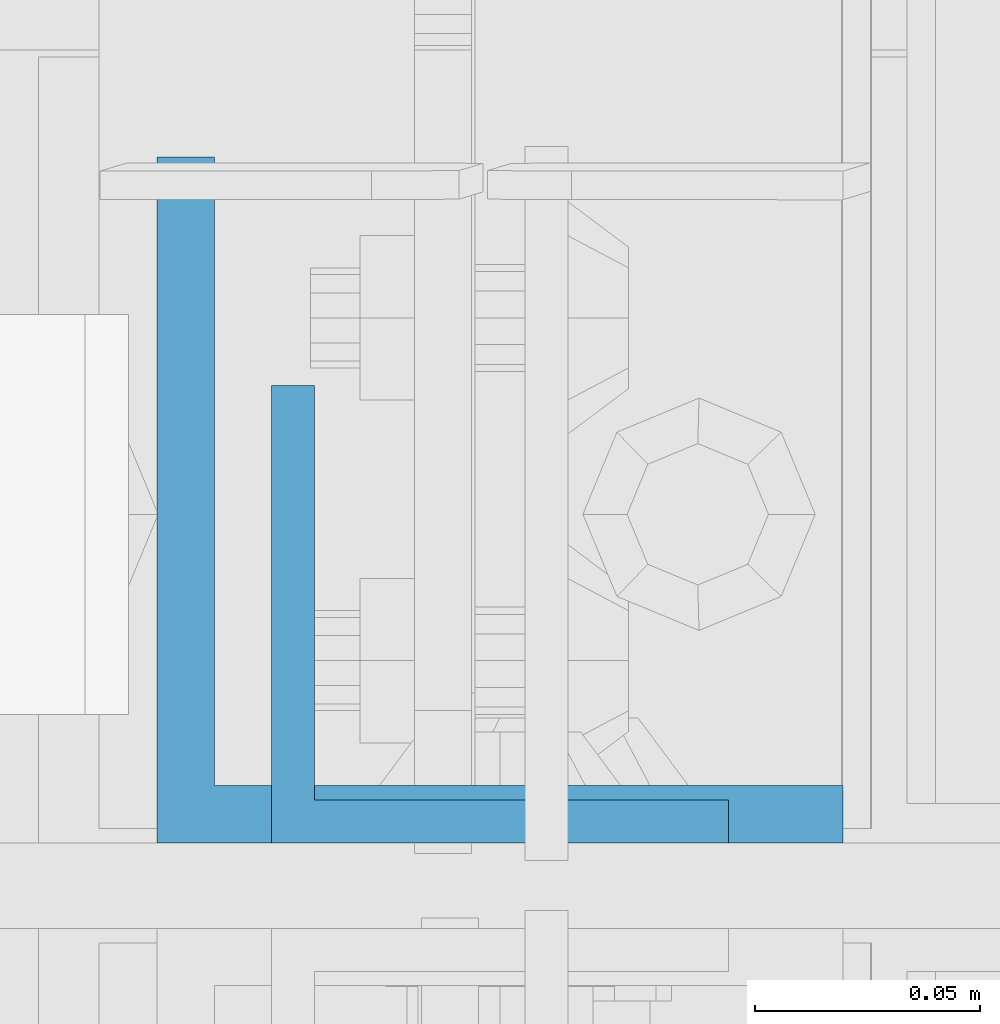
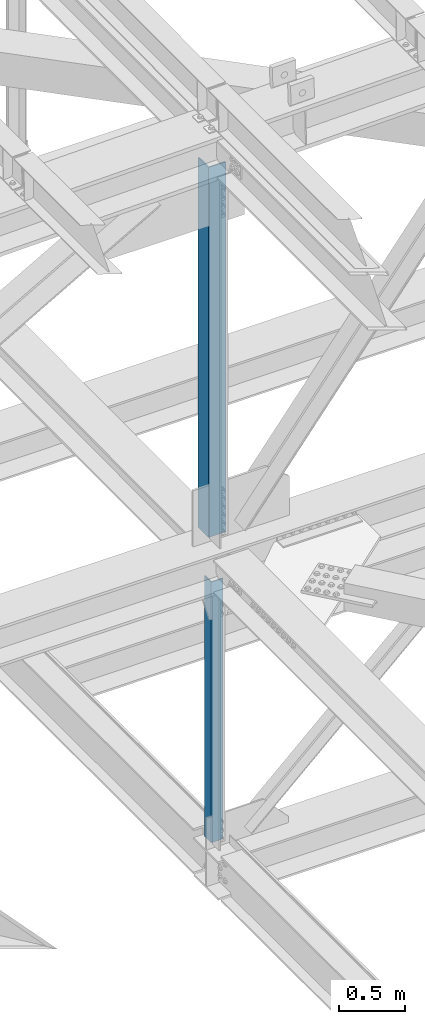
# One storey, part 1835 of 3843: 2 beams, 2 elements without a shape of their own.
"""IFC2X3 building model written with IfcOpenShell, lengths in millimetres."""

from ifc_helpers import new_model, si_unit, frame, origin_with_axes, place, context, subcontext, project, spatial, faceted_brep, material, type_object, element, aggregate, save


model = new_model("IFC2X3")

# Units and contexts
model_context = context("Model", 3, precision=1e-05, world=origin_with_axes())
body_context = subcontext(model_context, "Body", "Model", "MODEL_VIEW")
ifc_project = project(units=[si_unit("LENGTHUNIT", "METRE", prefix="MILLI"), si_unit("AREAUNIT", "SQUARE_METRE"), si_unit("VOLUMEUNIT", "CUBIC_METRE"), si_unit("MASSUNIT", "GRAM", prefix="KILO"), si_unit("TIMEUNIT", "SECOND"), si_unit("PLANEANGLEUNIT", "RADIAN"), si_unit("SOLIDANGLEUNIT", "STERADIAN"), si_unit("THERMODYNAMICTEMPERATUREUNIT", "DEGREE_CELSIUS"), si_unit("LUMINOUSINTENSITYUNIT", "LUMEN")], contexts=[model_context])

# Site, building, storey
site_placement = place(None, origin_with_axes())
site = spatial("IfcSite", under=ifc_project, at=site_placement, CompositionType="ELEMENT")
building_placement = place(site_placement, origin_with_axes())
building = spatial("IfcBuilding", under=site, at=building_placement, Name="Undefined", CompositionType="ELEMENT")
storey_placement = place(building_placement, origin_with_axes())
storey = spatial("IfcBuildingStorey", under=building, at=storey_placement, Name="Undefined", CompositionType="ELEMENT", Elevation=0.0)

# Assembly, beam
assembly_1_placement = place(storey_placement, origin_with_axes())
assembly_1 = element("IfcElementAssembly", 1, at=assembly_1_placement, inside=storey, Name="ANGLE", AssemblyPlace="NOTDEFINED", PredefinedType="RIGID_FRAME")
ifc_material = material(Name="STEEL/A572-50")
beam_type_1 = type_object("IfcBeamType", Name="L4X4X3/8", PredefinedType="NOTDEFINED")
beam_1_placement = place(assembly_1_placement, frame((77012.800000028, 33905.825, 42266.0734958762), z_axis=(0.0, 1.0, 0.0), x_axis=(0.0, 0.0, -1.0)))
beam_1 = element("IfcBeam", 2, at=beam_1_placement, type_object=beam_type_1, material=ifc_material, Name="ANGLE", ObjectType="L4X4X3/8", context=body_context, shape_type="Brep", body=[
    faceted_brep([(209.574551470876, 50.8000000000029, -50.8000000000029), (209.574551470876, 50.8000000000029, 50.8000000000029), (2603.58821558402, 50.8000000000029, 50.8000000000029), (2603.58821558402, 50.8000000000029, -50.8000000000029), (209.574551470876, 41.2749999999942, 50.8000000000029), (2603.58821558402, 41.2749999999942, 50.8000000000029), (209.574551470876, 41.2749999999942, -41.2750000000015), (2603.58821558402, 41.2749999999942, -41.2750000000015), (209.574551470876, -50.8000000000029, -41.2750000000015), (2603.58821558402, -50.8000000000029, -41.2750000000015), (209.574551470876, -50.8000000000029, -50.8000000000029), (2603.58821558402, -50.8000000000029, -50.8000000000029)], [[[0, 1, 2, 3]], [[1, 4, 5, 2]], [[4, 6, 7, 5]], [[6, 8, 9, 7]], [[8, 10, 11, 9]], [[10, 0, 3, 11]], [[5, 7, 9, 11, 3, 2]], [[10, 8, 6, 4, 1, 0]]]),
])
aggregate(assembly_1, [beam_1])

assembly_2_placement = place(storey_placement, origin_with_axes())
assembly_2 = element("IfcElementAssembly", 3, at=assembly_2_placement, inside=storey, Name="ANGLE", AssemblyPlace="NOTDEFINED", PredefinedType="RIGID_FRAME")
beam_type_2 = type_object("IfcBeamType", Name="L6X6X1/2", PredefinedType="NOTDEFINED")
beam_2_placement = place(assembly_2_placement, frame((77012.8, 33931.225, 46096.5035436108), z_axis=(0.0, 1.0, 0.0), x_axis=(0.0, 0.0, -1.0)))
beam_2 = element("IfcBeam", 4, at=beam_2_placement, type_object=beam_type_2, material=ifc_material, Name="ANGLE", ObjectType="L6X6X1/2", context=body_context, shape_type="Brep", body=[
    faceted_brep([(224.072059462451, 76.1999999999971, -76.1999999999971), (224.072059462451, 76.1999999999971, 76.1999999999971), (3621.52260546288, 76.1999999999971, 76.1999999999971), (3621.52260546288, 76.1999999999971, -76.1999999999971), (224.072059462451, 63.5, 76.1999999999971), (3621.52260546288, 63.5, 76.1999999999971), (224.072059462451, 63.5, -63.5), (3621.52260546288, 63.5, -63.5), (224.072059462451, -76.1999999999971, -63.5), (3621.52260546288, -76.1999999999971, -63.5), (224.072059462451, -76.1999999999971, -76.1999999999971), (3621.52260546288, -76.1999999999971, -76.1999999999971)], [[[0, 1, 2, 3]], [[1, 4, 5, 2]], [[4, 6, 7, 5]], [[6, 8, 9, 7]], [[8, 10, 11, 9]], [[10, 0, 3, 11]], [[5, 7, 9, 11, 3, 2]], [[10, 8, 6, 4, 1, 0]]]),
])
aggregate(assembly_2, [beam_2])

save(model, "model.ifc")
